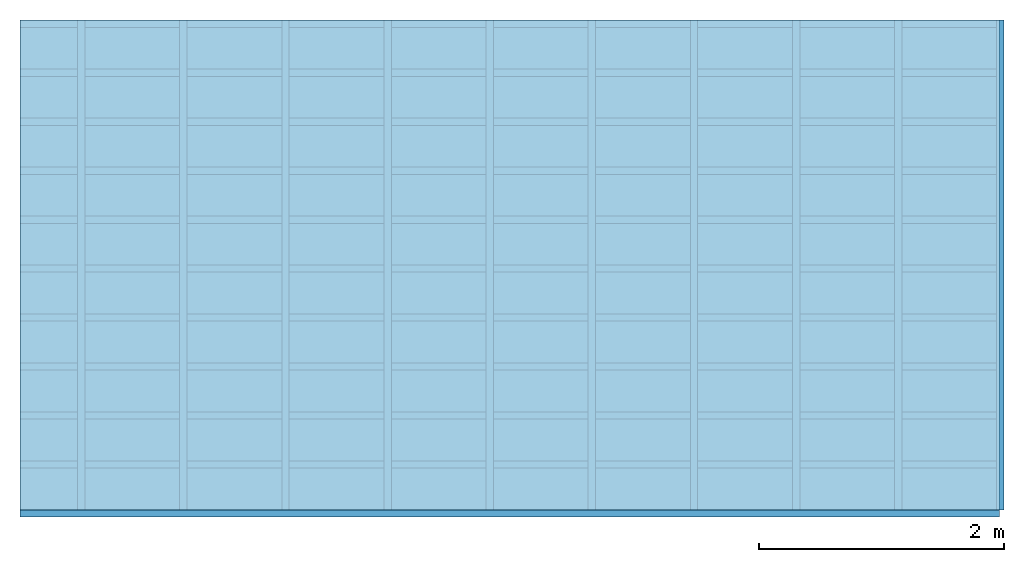
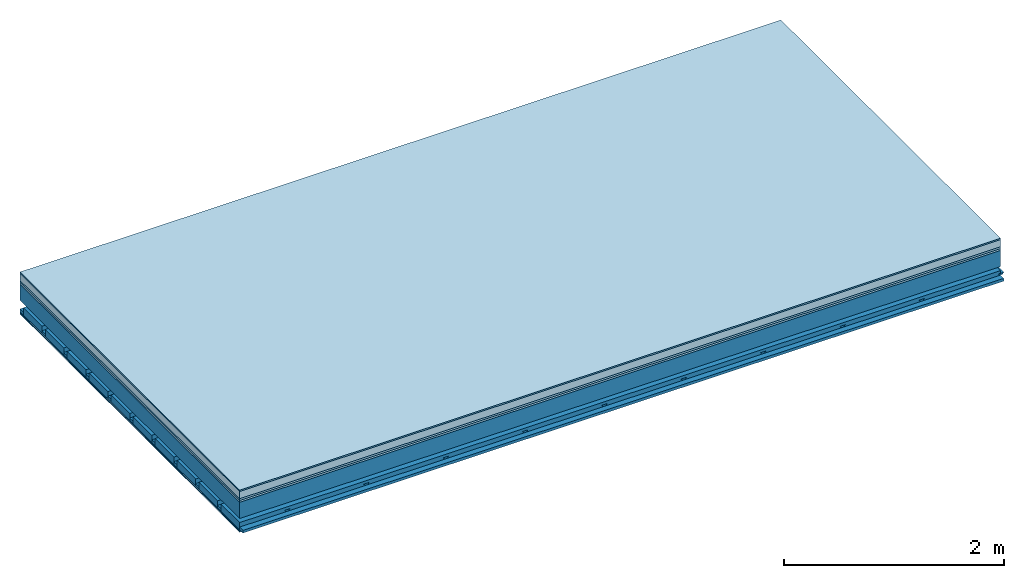
# One storey: 7 plates, 4 members, 1 element without a shape of its own.
"""IFC4 building model written with IfcOpenShell, lengths in metres."""

from ifc_helpers import new_model, si_unit, derived_unit, direction, frame, frame_2d, origin, origin_with_axes, place, context, project, spatial, polyline, rectangle, outline, extrude, material, layer, layer_set, type_object, element, aggregate, save


model = new_model("IFC4")

# Units and contexts
plan_context = context("Plan", 3, precision=1e-05, world=origin(), true_north=direction((0.0, 1.0)))
model_context = context("Model", 3, precision=1e-05, world=origin(), true_north=direction((0.0, 1.0)))
ifc_project = project(units=[si_unit("LENGTHUNIT", "METRE"), derived_unit("SOUNDPRESSUREUNIT", [(si_unit("PRESSUREUNIT", "PASCAL", prefix="MICRO"), 0)]), si_unit("ENERGYUNIT", "JOULE", prefix="MEGA"), si_unit("MASSUNIT", "GRAM", prefix="KILO"), derived_unit("THERMALTRANSMITTANCEUNIT", [(si_unit("POWERUNIT", "WATT"), 1), (si_unit("AREAUNIT", "SQUARE_METRE"), -1), (si_unit("THERMODYNAMICTEMPERATUREUNIT", "KELVIN"), -1)]), derived_unit("AREADENSITYUNIT", [(si_unit("MASSUNIT", "GRAM", prefix="KILO"), 1), (si_unit("AREAUNIT", "SQUARE_METRE"), -1)]), derived_unit("USERDEFINED", [(si_unit("ENERGYUNIT", "JOULE", prefix="MEGA"), 1), (si_unit("AREAUNIT", "SQUARE_METRE"), -1)])], contexts=[plan_context, model_context])

# Site, building, storey
site = spatial("IfcSite", under=ifc_project)
building_placement = place(None, origin())
building = spatial("IfcBuilding", under=site, at=building_placement)
storey_placement = place(building_placement, origin())
storey = spatial("IfcBuildingStorey", under=building, at=storey_placement)

# Slab, members, plates
ifc_material_1 = material(Category="11.013")
ifc_layer_1 = layer(ifc_material_1, 0.015, Name="Flooring")
ifc_material_2 = material(Name="Cement screed", Category="04.006")
ifc_layer_2 = layer(ifc_material_2, 0.08, Name="On-material")
ifc_material_3 = material(Name="Wood fiber generic product", Category="10.009")
ifc_layer_3 = layer(ifc_material_3, 0.02, Name="Impact sound insulation")
ifc_material_4 = material(Category="10.004")
ifc_layer_4 = layer(ifc_material_4, 0.02, Name="Additional insulation")
ifc_material_5 = material(Name="no composite action")
ifc_layer_5 = layer(ifc_material_5, 0.0, Name="Bond")
ifc_layer_6 = layer(None, 0.18, Name="Supporting structure")
ifc_layer_7 = layer(ifc_material_5, 0.0, Name="Bond")
ifc_layer_8 = layer(None, 0.095, Name="Coupling")
ifc_layer_9 = layer(None, 0.03, Name="Battens / profiles")
ifc_material_6 = material(Name="Plasterboard type A", Category="03.008")
ifc_layer_10 = layer(ifc_material_6, 0.0125, Name="Ceiling covering 1st layer")
ifc_layer_11 = layer(ifc_material_6, 0.0125, Name="Ceiling covering layer 2")
ifc_material_7 = material(Category="04.001")
ifc_layer_12 = layer(ifc_material_7, 0.003, Name="Surface / treatment")
ifc_layer_set = layer_set([ifc_layer_1, ifc_layer_2, ifc_layer_3, ifc_layer_4, ifc_layer_5, ifc_layer_6, ifc_layer_7, ifc_layer_8, ifc_layer_9, ifc_layer_10, ifc_layer_11, ifc_layer_12])
slab_type = type_object("IfcSlabType", Name="A2153", PredefinedType="NOTDEFINED", material=ifc_layer_set)
slab_placement = place(None, frame((0.0, 0.0, 0.0), z_axis=(0.0, 0.0, -1.0), x_axis=(1.0, 0.0, 0.0)))
slab = element("IfcSlab", 1, at=slab_placement, inside=storey, type_object=slab_type, material=ifc_layer_set, Name="Slab #1")
ifc_material_8 = material(Name="Solid timber panel")
member_1_placement = place(slab_placement, origin())
member_1 = element("IfcMember", 2, at=member_1_placement, material=ifc_material_8, Name="Supporting structure", context=plan_context, shape_type="SweptSolid", body=[
    extrude(rectangle(XDim=1.0, YDim=0.18, at=frame_2d((0.5, 0.09), x_axis=(1.0, 0.0))), frame((0.0, 4.0, 0.135), z_axis=(0.0, -1.0, 0.0), x_axis=(1.0, 0.0, 0.0)), (0.0, 0.0, 1.0), 4.0),
    extrude(rectangle(XDim=1.0, YDim=0.18, at=frame_2d((0.5, 0.09), x_axis=(1.0, 0.0))), frame((1.0, 4.0, 0.135), z_axis=(0.0, -1.0, 0.0), x_axis=(1.0, 0.0, 0.0)), (0.0, 0.0, 1.0), 4.0),
    extrude(rectangle(XDim=1.0, YDim=0.18, at=frame_2d((0.5, 0.09), x_axis=(1.0, 0.0))), frame((2.0, 4.0, 0.135), z_axis=(0.0, -1.0, 0.0), x_axis=(1.0, 0.0, 0.0)), (0.0, 0.0, 1.0), 4.0),
    extrude(rectangle(XDim=1.0, YDim=0.18, at=frame_2d((0.5, 0.09), x_axis=(1.0, 0.0))), frame((3.0, 4.0, 0.135), z_axis=(0.0, -1.0, 0.0), x_axis=(1.0, 0.0, 0.0)), (0.0, 0.0, 1.0), 4.0),
    extrude(rectangle(XDim=1.0, YDim=0.18, at=frame_2d((0.5, 0.09), x_axis=(1.0, 0.0))), frame((4.0, 4.0, 0.135), z_axis=(0.0, -1.0, 0.0), x_axis=(1.0, 0.0, 0.0)), (0.0, 0.0, 1.0), 4.0),
    extrude(rectangle(XDim=1.0, YDim=0.18, at=frame_2d((0.5, 0.09), x_axis=(1.0, 0.0))), frame((5.0, 4.0, 0.135), z_axis=(0.0, -1.0, 0.0), x_axis=(1.0, 0.0, 0.0)), (0.0, 0.0, 1.0), 4.0),
    extrude(rectangle(XDim=1.0, YDim=0.18, at=frame_2d((0.5, 0.09), x_axis=(1.0, 0.0))), frame((6.0, 4.0, 0.135), z_axis=(0.0, -1.0, 0.0), x_axis=(1.0, 0.0, 0.0)), (0.0, 0.0, 1.0), 4.0),
    extrude(rectangle(XDim=1.0, YDim=0.18, at=frame_2d((0.5, 0.09), x_axis=(1.0, 0.0))), frame((7.0, 4.0, 0.135), z_axis=(0.0, -1.0, 0.0), x_axis=(1.0, 0.0, 0.0)), (0.0, 0.0, 1.0), 4.0),
])
ifc_material_9 = material()
member_2_placement = place(slab_placement, origin())
member_2 = element("IfcMember", 3, at=member_2_placement, material=ifc_material_9, Name="Coupling", context=plan_context, shape_type="SweptSolid", body=[
    extrude(outline(polyline([(0.0, 0.0), (0.06, 0.0), (0.04, 0.02), (0.02, 0.02), (0.0, 0.0)])), frame((0.47, 4.0, 0.39), z_axis=(0.0, -1.0, 0.0), x_axis=(1.0, 0.0, 0.0)), (0.0, 0.0, 1.0), 4.0),
    extrude(outline(polyline([(0.0, 0.0), (0.06, 0.0), (0.04, 0.02), (0.02, 0.02), (0.0, 0.0)])), frame((1.304, 4.0, 0.39), z_axis=(0.0, -1.0, 0.0), x_axis=(1.0, 0.0, 0.0)), (0.0, 0.0, 1.0), 4.0),
    extrude(outline(polyline([(0.0, 0.0), (0.06, 0.0), (0.04, 0.02), (0.02, 0.02), (0.0, 0.0)])), frame((2.138, 4.0, 0.39), z_axis=(0.0, -1.0, 0.0), x_axis=(1.0, 0.0, 0.0)), (0.0, 0.0, 1.0), 4.0),
    extrude(outline(polyline([(0.0, 0.0), (0.06, 0.0), (0.04, 0.02), (0.02, 0.02), (0.0, 0.0)])), frame((2.972, 4.0, 0.39), z_axis=(0.0, -1.0, 0.0), x_axis=(1.0, 0.0, 0.0)), (0.0, 0.0, 1.0), 4.0),
    extrude(outline(polyline([(0.0, 0.0), (0.06, 0.0), (0.04, 0.02), (0.02, 0.02), (0.0, 0.0)])), frame((3.806, 4.0, 0.39), z_axis=(0.0, -1.0, 0.0), x_axis=(1.0, 0.0, 0.0)), (0.0, 0.0, 1.0), 4.0),
    extrude(outline(polyline([(0.0, 0.0), (0.06, 0.0), (0.04, 0.02), (0.02, 0.02), (0.0, 0.0)])), frame((4.64, 4.0, 0.39), z_axis=(0.0, -1.0, 0.0), x_axis=(1.0, 0.0, 0.0)), (0.0, 0.0, 1.0), 4.0),
    extrude(outline(polyline([(0.0, 0.0), (0.06, 0.0), (0.04, 0.02), (0.02, 0.02), (0.0, 0.0)])), frame((5.474, 4.0, 0.39), z_axis=(0.0, -1.0, 0.0), x_axis=(1.0, 0.0, 0.0)), (0.0, 0.0, 1.0), 4.0),
    extrude(outline(polyline([(0.0, 0.0), (0.06, 0.0), (0.04, 0.02), (0.02, 0.02), (0.0, 0.0)])), frame((6.308, 4.0, 0.39), z_axis=(0.0, -1.0, 0.0), x_axis=(1.0, 0.0, 0.0)), (0.0, 0.0, 1.0), 4.0),
    extrude(outline(polyline([(0.0, 0.0), (0.06, 0.0), (0.04, 0.02), (0.02, 0.02), (0.0, 0.0)])), frame((7.142, 4.0, 0.39), z_axis=(0.0, -1.0, 0.0), x_axis=(1.0, 0.0, 0.0)), (0.0, 0.0, 1.0), 4.0),
    extrude(outline(polyline([(0.0, 0.0), (0.06, 0.0), (0.04, 0.02), (0.02, 0.02), (0.0, 0.0)])), frame((7.976, 4.0, 0.39), z_axis=(0.0, -1.0, 0.0), x_axis=(1.0, 0.0, 0.0)), (0.0, 0.0, 1.0), 4.0),
])
member_3_placement = place(slab_placement, origin())
member_3 = element("IfcMember", 4, at=member_3_placement, material=ifc_material_9, Name="Battens / profiles", context=plan_context, shape_type="SweptSolid", body=[
    extrude(rectangle(XDim=0.06, YDim=0.03, at=frame_2d((0.03, 0.015), x_axis=(1.0, 0.0))), frame((0.0, 0.0, 0.41), z_axis=(1.0, 0.0, 0.0), x_axis=(0.0, 1.0, 0.0)), (0.0, 0.0, 1.0), 8.0),
    extrude(rectangle(XDim=0.06, YDim=0.03, at=frame_2d((0.03, 0.015), x_axis=(1.0, 0.0))), frame((0.0, 0.4, 0.41), z_axis=(1.0, 0.0, 0.0), x_axis=(0.0, 1.0, 0.0)), (0.0, 0.0, 1.0), 8.0),
    extrude(rectangle(XDim=0.06, YDim=0.03, at=frame_2d((0.03, 0.015), x_axis=(1.0, 0.0))), frame((0.0, 0.8, 0.41), z_axis=(1.0, 0.0, 0.0), x_axis=(0.0, 1.0, 0.0)), (0.0, 0.0, 1.0), 8.0),
    extrude(rectangle(XDim=0.06, YDim=0.03, at=frame_2d((0.03, 0.015), x_axis=(1.0, 0.0))), frame((0.0, 1.2, 0.41), z_axis=(1.0, 0.0, 0.0), x_axis=(0.0, 1.0, 0.0)), (0.0, 0.0, 1.0), 8.0),
    extrude(rectangle(XDim=0.06, YDim=0.03, at=frame_2d((0.03, 0.015), x_axis=(1.0, 0.0))), frame((0.0, 1.6, 0.41), z_axis=(1.0, 0.0, 0.0), x_axis=(0.0, 1.0, 0.0)), (0.0, 0.0, 1.0), 8.0),
    extrude(rectangle(XDim=0.06, YDim=0.03, at=frame_2d((0.03, 0.015), x_axis=(1.0, 0.0))), frame((0.0, 2.0, 0.41), z_axis=(1.0, 0.0, 0.0), x_axis=(0.0, 1.0, 0.0)), (0.0, 0.0, 1.0), 8.0),
    extrude(rectangle(XDim=0.06, YDim=0.03, at=frame_2d((0.03, 0.015), x_axis=(1.0, 0.0))), frame((0.0, 2.4, 0.41), z_axis=(1.0, 0.0, 0.0), x_axis=(0.0, 1.0, 0.0)), (0.0, 0.0, 1.0), 8.0),
    extrude(rectangle(XDim=0.06, YDim=0.03, at=frame_2d((0.03, 0.015), x_axis=(1.0, 0.0))), frame((0.0, 2.8, 0.41), z_axis=(1.0, 0.0, 0.0), x_axis=(0.0, 1.0, 0.0)), (0.0, 0.0, 1.0), 8.0),
    extrude(rectangle(XDim=0.06, YDim=0.03, at=frame_2d((0.03, 0.015), x_axis=(1.0, 0.0))), frame((0.0, 3.2, 0.41), z_axis=(1.0, 0.0, 0.0), x_axis=(0.0, 1.0, 0.0)), (0.0, 0.0, 1.0), 8.0),
    extrude(rectangle(XDim=0.06, YDim=0.03, at=frame_2d((0.03, 0.015), x_axis=(1.0, 0.0))), frame((0.0, 3.6, 0.41), z_axis=(1.0, 0.0, 0.0), x_axis=(0.0, 1.0, 0.0)), (0.0, 0.0, 1.0), 8.0),
    extrude(rectangle(XDim=0.06, YDim=0.03, at=frame_2d((0.03, 0.015), x_axis=(1.0, 0.0))), frame((0.0, 4.0, 0.41), z_axis=(1.0, 0.0, 0.0), x_axis=(0.0, 1.0, 0.0)), (0.0, 0.0, 1.0), 8.0),
])
ifc_material_10 = material()
member_4_placement = place(slab_placement, origin())
member_4 = element("IfcMember", 5, at=member_4_placement, material=ifc_material_10, Name="Cavity", context=plan_context, shape_type="SweptSolid", body=[
    extrude(rectangle(XDim=0.34, YDim=0.08, at=frame_2d((0.17, 0.04), x_axis=(1.0, 0.0))), frame((0.0, 0.06, 0.36), z_axis=(1.0, 0.0, 0.0), x_axis=(0.0, 1.0, 0.0)), (0.0, 0.0, 1.0), 8.0),
    extrude(rectangle(XDim=0.34, YDim=0.08, at=frame_2d((0.17, 0.04), x_axis=(1.0, 0.0))), frame((0.0, 0.46, 0.36), z_axis=(1.0, 0.0, 0.0), x_axis=(0.0, 1.0, 0.0)), (0.0, 0.0, 1.0), 8.0),
    extrude(rectangle(XDim=0.34, YDim=0.08, at=frame_2d((0.17, 0.04), x_axis=(1.0, 0.0))), frame((0.0, 0.86, 0.36), z_axis=(1.0, 0.0, 0.0), x_axis=(0.0, 1.0, 0.0)), (0.0, 0.0, 1.0), 8.0),
    extrude(rectangle(XDim=0.34, YDim=0.08, at=frame_2d((0.17, 0.04), x_axis=(1.0, 0.0))), frame((0.0, 1.26, 0.36), z_axis=(1.0, 0.0, 0.0), x_axis=(0.0, 1.0, 0.0)), (0.0, 0.0, 1.0), 8.0),
    extrude(rectangle(XDim=0.34, YDim=0.08, at=frame_2d((0.17, 0.04), x_axis=(1.0, 0.0))), frame((0.0, 1.66, 0.36), z_axis=(1.0, 0.0, 0.0), x_axis=(0.0, 1.0, 0.0)), (0.0, 0.0, 1.0), 8.0),
    extrude(rectangle(XDim=0.34, YDim=0.08, at=frame_2d((0.17, 0.04), x_axis=(1.0, 0.0))), frame((0.0, 2.06, 0.36), z_axis=(1.0, 0.0, 0.0), x_axis=(0.0, 1.0, 0.0)), (0.0, 0.0, 1.0), 8.0),
    extrude(rectangle(XDim=0.34, YDim=0.08, at=frame_2d((0.17, 0.04), x_axis=(1.0, 0.0))), frame((0.0, 2.46, 0.36), z_axis=(1.0, 0.0, 0.0), x_axis=(0.0, 1.0, 0.0)), (0.0, 0.0, 1.0), 8.0),
    extrude(rectangle(XDim=0.34, YDim=0.08, at=frame_2d((0.17, 0.04), x_axis=(1.0, 0.0))), frame((0.0, 2.86, 0.36), z_axis=(1.0, 0.0, 0.0), x_axis=(0.0, 1.0, 0.0)), (0.0, 0.0, 1.0), 8.0),
    extrude(rectangle(XDim=0.34, YDim=0.08, at=frame_2d((0.17, 0.04), x_axis=(1.0, 0.0))), frame((0.0, 3.26, 0.36), z_axis=(1.0, 0.0, 0.0), x_axis=(0.0, 1.0, 0.0)), (0.0, 0.0, 1.0), 8.0),
    extrude(rectangle(XDim=0.34, YDim=0.08, at=frame_2d((0.17, 0.04), x_axis=(1.0, 0.0))), frame((0.0, 3.66, 0.36), z_axis=(1.0, 0.0, 0.0), x_axis=(0.0, 1.0, 0.0)), (0.0, 0.0, 1.0), 8.0),
])
plate_1_placement = place(slab_placement, origin())
plate_1 = element("IfcPlate", 6, at=plate_1_placement, material=ifc_material_1, Name="Flooring", context=plan_context, shape_type="SweptSolid", body=[
    extrude(rectangle(XDim=8.0, YDim=4.0, at=frame_2d((4.0, 2.0), x_axis=(1.0, 0.0))), origin_with_axes(), (0.0, 0.0, 1.0), 0.015),
])
plate_2_placement = place(slab_placement, origin())
plate_2 = element("IfcPlate", 7, at=plate_2_placement, material=ifc_material_2, Name="On-material", context=plan_context, shape_type="SweptSolid", body=[
    extrude(rectangle(XDim=8.0, YDim=4.0, at=frame_2d((4.0, 2.0), x_axis=(1.0, 0.0))), frame((0.0, 0.0, 0.015), z_axis=(0.0, 0.0, 1.0), x_axis=(1.0, 0.0, 0.0)), (0.0, 0.0, 1.0), 0.08),
])
plate_3_placement = place(slab_placement, origin())
plate_3 = element("IfcPlate", 8, at=plate_3_placement, material=ifc_material_3, Name="Impact sound insulation", context=plan_context, shape_type="SweptSolid", body=[
    extrude(rectangle(XDim=8.0, YDim=4.0, at=frame_2d((4.0, 2.0), x_axis=(1.0, 0.0))), frame((0.0, 0.0, 0.095), z_axis=(0.0, 0.0, 1.0), x_axis=(1.0, 0.0, 0.0)), (0.0, 0.0, 1.0), 0.02),
])
plate_4_placement = place(slab_placement, origin())
plate_4 = element("IfcPlate", 9, at=plate_4_placement, material=ifc_material_4, Name="Additional insulation", context=plan_context, shape_type="SweptSolid", body=[
    extrude(rectangle(XDim=8.0, YDim=4.0, at=frame_2d((4.0, 2.0), x_axis=(1.0, 0.0))), frame((0.0, 0.0, 0.115), z_axis=(0.0, 0.0, 1.0), x_axis=(1.0, 0.0, 0.0)), (0.0, 0.0, 1.0), 0.02),
])
plate_5_placement = place(slab_placement, origin())
plate_5 = element("IfcPlate", 10, at=plate_5_placement, material=ifc_material_6, Name="Ceiling covering 1st layer", context=plan_context, shape_type="SweptSolid", body=[
    extrude(rectangle(XDim=8.0, YDim=4.0, at=frame_2d((4.0, 2.0), x_axis=(1.0, 0.0))), frame((0.0, 0.0, 0.44), z_axis=(0.0, 0.0, 1.0), x_axis=(1.0, 0.0, 0.0)), (0.0, 0.0, 1.0), 0.0125),
])
plate_6_placement = place(slab_placement, origin())
plate_6 = element("IfcPlate", 11, at=plate_6_placement, material=ifc_material_6, Name="Ceiling covering layer 2", context=plan_context, shape_type="SweptSolid", body=[
    extrude(rectangle(XDim=8.0, YDim=4.0, at=frame_2d((4.0, 2.0), x_axis=(1.0, 0.0))), frame((0.0, 0.0, 0.4525), z_axis=(0.0, 0.0, 1.0), x_axis=(1.0, 0.0, 0.0)), (0.0, 0.0, 1.0), 0.0125),
])
plate_7_placement = place(slab_placement, origin())
plate_7 = element("IfcPlate", 12, at=plate_7_placement, material=ifc_material_7, Name="Surface / treatment", context=plan_context, shape_type="SweptSolid", body=[
    extrude(rectangle(XDim=8.0, YDim=4.0, at=frame_2d((4.0, 2.0), x_axis=(1.0, 0.0))), frame((0.0, 0.0, 0.465), z_axis=(0.0, 0.0, 1.0), x_axis=(1.0, 0.0, 0.0)), (0.0, 0.0, 1.0), 0.003),
])
aggregate(slab, [plate_1, plate_2, plate_3, plate_4, member_1, member_2, member_3, member_4, plate_5, plate_6, plate_7])

save(model, "model.ifc")
